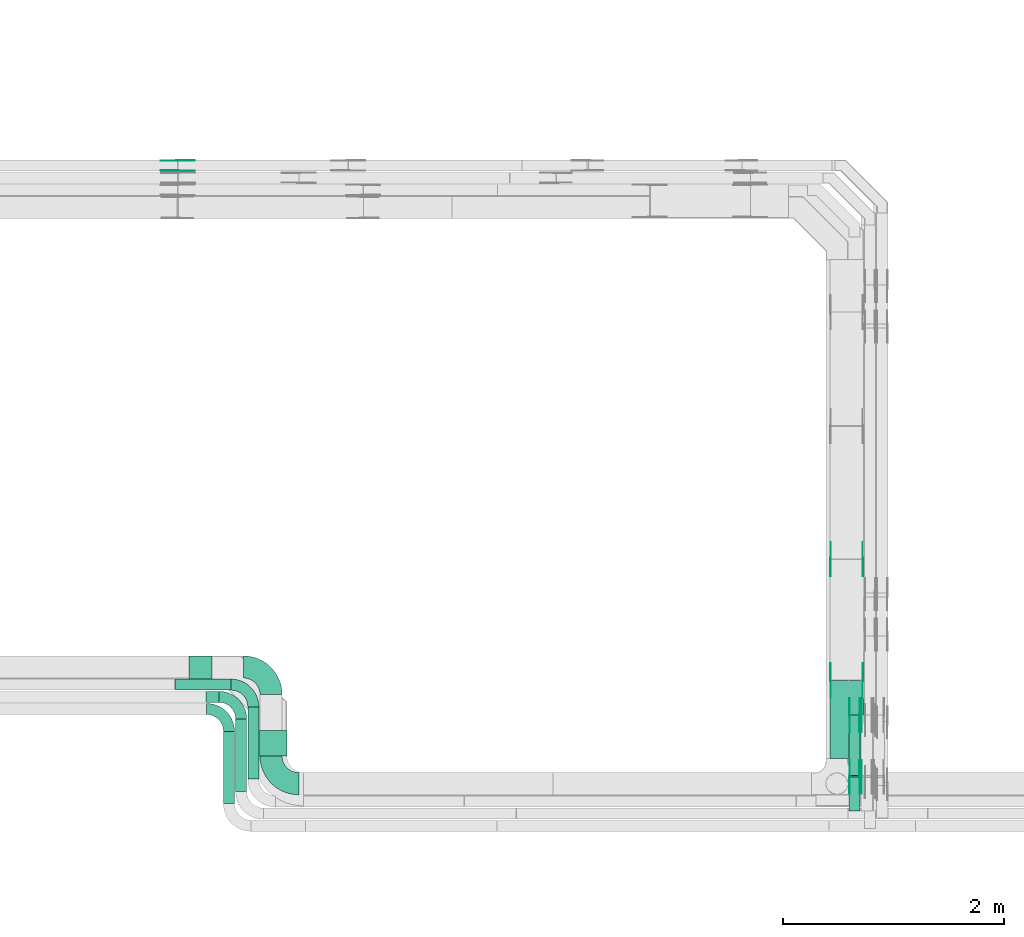
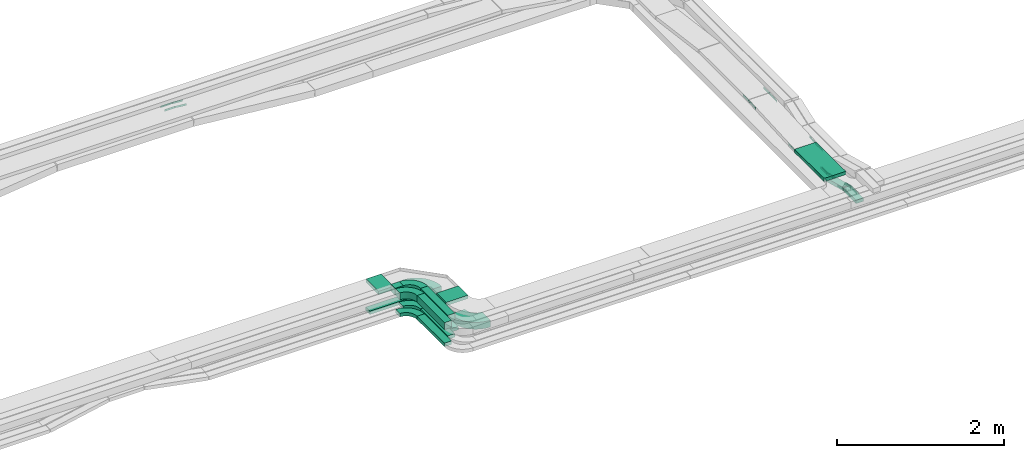
# One storey, part 23 of 33: 31 flow fittings, 12 flow segments.
"""IFC2X3 building model written with IfcOpenShell, lengths in millimetres."""

import ifcopenshell
import ifcopenshell.guid

model = None  # the IFC model being written
_history = None  # IfcOwnerHistory: only IFC2X3 demands one
_inside = {}  # id of a spatial element -> (the spatial element, [elements in it])
_under = {}  # id of a project, library or spatial element -> (it, [spatial elements below it])
_declared = {}  # id of a project -> (the project, [libraries it declares])
_typed = {}  # id of a type object -> (the type object, [elements of that type])
_made_of = {}  # id of a material, layer set ... -> (it, [elements and type objects made of it])


def new_model(schema):
    """Start an empty IFC model of exactly this schema.

    Asked for "IFC4X3", IfcOpenShell would pick the latest addendum, in which some entities
    have other attributes; the version numbers below select the first issue.
    IFC2X3 requires an IfcOwnerHistory on every rooted entity: one is made here for all.
    """
    global model, _history
    if schema == "IFC4X3":
        model = ifcopenshell.file(schema_version=(4, 3, 0, 0))
    else:
        model = ifcopenshell.file(schema=schema)
    _inside.clear()
    _under.clear()
    _declared.clear()
    _typed.clear()
    _made_of.clear()
    _history = None
    if model.schema == "IFC2X3":
        org = make("IfcOrganization", Name="unknown")
        user = make(
            "IfcPersonAndOrganization",
            ThePerson=make("IfcPerson", FamilyName="unknown"),
            TheOrganization=org,
        )
        app = make(
            "IfcApplication",
            ApplicationDeveloper=org,
            Version="unknown",
            ApplicationFullName="unknown",
            ApplicationIdentifier="unknown",
        )
        _history = make(
            "IfcOwnerHistory",
            OwningUser=user,
            OwningApplication=app,
            ChangeAction="ADDED",
            CreationDate=0,
        )
    return model


def make(cls, **values):
    """One entity of the class cls with the attributes given. An attribute that is None is left unset."""
    return model.create_entity(
        cls, **{name: value for name, value in values.items() if value is not None}
    )


def entity(cls, *values):
    """Any entity or typed value of the class cls, its attributes in the order of the schema. None: left unset."""
    e = model.create_entity(cls)
    for i, value in enumerate(values):
        if value is not None:
            e[i] = value
    return e


def rooted(cls, **values):
    """An entity with a GlobalId (a new one), such as an element, a storey or a relation."""
    return make(cls, GlobalId=ifcopenshell.guid.new(), OwnerHistory=_history, **values)


def si_unit(unit_type, name, prefix=None):
    """IfcSIUnit, for example si_unit("LENGTHUNIT", "METRE", prefix="MILLI")."""
    return make("IfcSIUnit", UnitType=unit_type, Prefix=prefix, Name=name)


def converted_unit(unit_type, name, factor, base, dimensions=None, offset=None):
    """IfcConversionBasedUnit, such as the inch: factor (a typed value) times the base unit."""
    return make(
        "IfcConversionBasedUnit"
        if offset is None
        else "IfcConversionBasedUnitWithOffset",
        ConversionOffset=offset,
        Dimensions=None
        if dimensions is None
        else entity("IfcDimensionalExponents", *dimensions),
        UnitType=unit_type,
        Name=name,
        ConversionFactor=make(
            "IfcMeasureWithUnit", ValueComponent=factor, UnitComponent=base
        ),
    )


def derived_unit(unit_type, elements):
    """IfcDerivedUnit: a product of units, each with its exponent."""
    return make(
        "IfcDerivedUnit",
        Elements=[
            make("IfcDerivedUnitElement", Unit=unit, Exponent=power)
            for unit, power in elements
        ],
        UnitType=unit_type,
    )


def assignment(units):
    """IfcUnitAssignment: the units of a project."""
    return None if units is None else make("IfcUnitAssignment", Units=units)


def point(xyz):
    """IfcCartesianPoint."""
    return None if xyz is None else make("IfcCartesianPoint", Coordinates=xyz)


def direction(xyz):
    """IfcDirection."""
    return None if xyz is None else make("IfcDirection", DirectionRatios=xyz)


def frame(location, z_axis=None, x_axis=None):
    """IfcAxis2Placement3D, a coordinate frame: its origin and axes. An axis left out is left unset."""
    return make(
        "IfcAxis2Placement3D",
        Location=point(location),
        Axis=direction(z_axis),
        RefDirection=direction(x_axis),
    )


def frame_2d(location, x_axis=None):
    """IfcAxis2Placement2D, a coordinate frame in the plane: its origin and x axis."""
    return make(
        "IfcAxis2Placement2D", Location=point(location), RefDirection=direction(x_axis)
    )


def origin():
    """The frame at (0, 0, 0) with its axes left unset."""
    return frame((0.0, 0.0, 0.0))


def origin_2d_with_axis():
    """The frame at (0, 0) in the plane with the x axis (1, 0) written out."""
    return frame_2d((0.0, 0.0), x_axis=(1.0, 0.0))


def place(relative_to, where):
    """IfcLocalPlacement: puts the frame where relative to a parent placement (None: the world)."""
    return make(
        "IfcLocalPlacement", PlacementRelTo=relative_to, RelativePlacement=where
    )


def context(
    kind, dimensions, precision=None, world=None, true_north=None, identifier=None
):
    """IfcGeometricRepresentationContext, for example the 3D "Model" context."""
    return make(
        "IfcGeometricRepresentationContext",
        ContextIdentifier=identifier,
        ContextType=kind,
        CoordinateSpaceDimension=dimensions,
        Precision=precision,
        WorldCoordinateSystem=world,
        TrueNorth=true_north,
    )


def subcontext(parent, identifier, kind, view, scale=None):
    """IfcGeometricRepresentationSubContext, for example "Body" below "Model"."""
    return make(
        "IfcGeometricRepresentationSubContext",
        ContextIdentifier=identifier,
        ContextType=kind,
        ParentContext=parent,
        TargetScale=scale,
        TargetView=view,
    )


def project(units=None, contexts=None):
    """IfcProject with its units and contexts."""
    return rooted(
        "IfcProject",
        Name="project",
        RepresentationContexts=contexts,
        UnitsInContext=assignment(units),
    )


def spatial(cls, under=None, at=None, **own):
    """A site, building, storey or space (cls), placed at a placement, below another one or the project."""
    s = rooted(cls, ObjectPlacement=at, **own)
    if under is not None:
        _under.setdefault(under.id(), (under, []))[1].append(s)
    return s


def polyline(points):
    """IfcPolyline through the points."""
    return make("IfcPolyline", Points=[point(p) for p in points])


def circle_curve(where, radius):
    """IfcCircle in the frame where."""
    return make("IfcCircle", Position=where, Radius=radius)


def parameter(value):
    """IfcParameterValue: where a trimmed curve begins or ends, as a parameter of its basis curve."""
    return model.create_entity("IfcParameterValue", value)


def trimmed(basis, trim1, trim2, sense, master):
    """IfcTrimmedCurve: the piece of a basis curve between two trims."""
    return make(
        "IfcTrimmedCurve",
        BasisCurve=basis,
        Trim1=trim1,
        Trim2=trim2,
        SenseAgreement=sense,
        MasterRepresentation=master,
    )


def segment(curve, same_sense, transition):
    """IfcCompositeCurveSegment."""
    return make(
        "IfcCompositeCurveSegment",
        Transition=transition,
        SameSense=same_sense,
        ParentCurve=curve,
    )


def composite_curve(segments, self_intersect=None):
    """IfcCompositeCurve: segments joined end to end."""
    return make("IfcCompositeCurve", Segments=segments, SelfIntersect=self_intersect)


def profile(cls, at=None, kind="AREA", **sizes):
    """A parametric profile (cls). Its sizes go by their IFC names, for example OverallWidth=200.0."""
    return make(cls, ProfileType=kind, Position=at, **sizes)


def rectangle(**sizes):
    """IfcRectangleProfileDef."""
    return profile("IfcRectangleProfileDef", **sizes)


def outline(outer, holes=None, kind="AREA"):
    """IfcArbitraryClosedProfileDef: a profile drawn as a closed curve; with holes, ...WithVoids."""
    if holes is None:
        return make("IfcArbitraryClosedProfileDef", ProfileType=kind, OuterCurve=outer)
    return make(
        "IfcArbitraryProfileDefWithVoids",
        ProfileType=kind,
        OuterCurve=outer,
        InnerCurves=holes,
    )


def extrude(swept, where, along, depth):
    """IfcExtrudedAreaSolid: the profile swept, set in the frame where, extruded along a direction by depth."""
    return make(
        "IfcExtrudedAreaSolid",
        SweptArea=swept,
        Position=where,
        ExtrudedDirection=direction(along),
        Depth=depth,
    )


def shape(context_of_items, identifier, shape_type, items):
    """IfcShapeRepresentation: the items that make up one representation, for example the "Body"."""
    return make(
        "IfcShapeRepresentation",
        ContextOfItems=context_of_items,
        RepresentationIdentifier=identifier,
        RepresentationType=shape_type,
        Items=items,
    )


def source(mapping_origin, context_of_items, identifier, shape_type, items):
    """IfcRepresentationMap: a shape defined once, which mapped items show again and again."""
    return make(
        "IfcRepresentationMap",
        MappingOrigin=mapping_origin,
        MappedRepresentation=shape(context_of_items, identifier, shape_type, items),
    )


def transform(
    local_origin,
    x_axis=None,
    y_axis=None,
    z_axis=None,
    scale=None,
    scale2=None,
    scale3=None,
    uniform=True,
):
    """IfcCartesianTransformationOperator3D, or its non-uniform kind. x_axis, y_axis, z_axis: its Axis1, 2, 3."""
    if uniform:
        return make(
            "IfcCartesianTransformationOperator3D",
            Axis1=direction(x_axis),
            Axis2=direction(y_axis),
            LocalOrigin=point(local_origin),
            Scale=scale,
            Axis3=direction(z_axis),
        )
    return make(
        "IfcCartesianTransformationOperator3DnonUniform",
        Axis1=direction(x_axis),
        Axis2=direction(y_axis),
        LocalOrigin=point(local_origin),
        Scale=scale,
        Axis3=direction(z_axis),
        Scale2=scale2,
        Scale3=scale3,
    )


def mapped(mapping_source, mapping_target):
    """IfcMappedItem: shows the shape of a source again, moved by a transform."""
    return make(
        "IfcMappedItem", MappingSource=mapping_source, MappingTarget=mapping_target
    )


def material(Name=None, Category=None):
    """IfcMaterial."""
    return make("IfcMaterial", Name=Name, Category=Category)


def made_of(thing, what):
    """Note that an element or type object is made of a material, layer set ...; save() writes the relation."""
    if what is not None:
        _made_of.setdefault(what.id(), (what, []))[1].append(thing)
    return thing


def type_object(cls, material=None, **own):
    """A type object (cls), such as IfcWallType, which elements share."""
    return made_of(rooted(cls, **own), material)


def type_shapes(of_type, sources):
    """Give a type object the sources (RepresentationMaps) that its elements show as mapped items."""
    of_type.RepresentationMaps = sources


def element(
    cls,
    number,
    at=None,
    inside=None,
    cuts=None,
    type_object=None,
    material=None,
    context=None,
    identifier="Body",
    shape_type=None,
    held_by="IfcProductDefinitionShape",
    body=None,
    shapes=None,
    **own,
):
    """One element of the class cls, such as IfcWall. Its Tag is "e" and its number.

    at: its placement. inside: the storey or other place that contains it. cuts: it is an
    opening in that element (IfcRelVoidsElement). A single representation is given by context,
    identifier, shape_type and body (its items); several are given by shapes. held_by: the class
    of the entity that holds the representations. save() writes the other relations.
    """
    e = rooted(cls, Tag="e%d" % number, ObjectPlacement=at, **own)
    if body is not None:
        shapes = [shape(context, identifier, shape_type, body)]
    if shapes is not None:
        e.Representation = make(held_by, Representations=shapes)
    if inside is not None:
        _inside.setdefault(inside.id(), (inside, []))[1].append(e)
    if cuts is not None:
        rooted(
            "IfcRelVoidsElement", RelatingBuildingElement=cuts, RelatedOpeningElement=e
        )
    if type_object is not None:
        _typed.setdefault(type_object.id(), (type_object, []))[1].append(e)
    return made_of(e, material)


def aggregate(whole, parts):
    """IfcRelAggregates: a whole, such as a stair, and the parts it consists of."""
    return rooted("IfcRelAggregates", RelatingObject=whole, RelatedObjects=parts)


def save(model, path):
    """Write the relations noted so far, then the file.

    IfcRelAggregates (storeys below a building ...), IfcRelContainedInSpatialStructure (elements
    in a storey), IfcRelDefinesByType, IfcRelAssociatesMaterial and IfcRelDeclares: one each for
    every whole, place, type object, material and project.
    """
    for whole, parts in _under.values():
        aggregate(whole, parts)
    for where, things in _inside.values():
        rooted(
            "IfcRelContainedInSpatialStructure",
            RelatedElements=things,
            RelatingStructure=where,
        )
    for kind, things in _typed.values():
        rooted("IfcRelDefinesByType", RelatedObjects=things, RelatingType=kind)
    for what, things in _made_of.values():
        rooted("IfcRelAssociatesMaterial", RelatedObjects=things, RelatingMaterial=what)
    for by, libraries in _declared.values():
        rooted("IfcRelDeclares", RelatingContext=by, RelatedDefinitions=libraries)
    model.write(path)


model = new_model("IFC2X3")

# Units and contexts
model_context = context("Model", 3, precision=0.01, world=origin(), true_north=direction((6.12303176911189e-17, 1.0)))
body_context = subcontext(model_context, "Body", "Model", "MODEL_VIEW")
ifc_project = project(units=[si_unit("LENGTHUNIT", "METRE", prefix="MILLI"), si_unit("AREAUNIT", "SQUARE_METRE"), si_unit("VOLUMEUNIT", "CUBIC_METRE"), converted_unit("PLANEANGLEUNIT", "DEGREE", entity("IfcRatioMeasure", 0.0174532925199433), si_unit("PLANEANGLEUNIT", "RADIAN"), dimensions=[0, 0, 0, 0, 0, 0, 0]), si_unit("MASSUNIT", "GRAM", prefix="KILO"), derived_unit("MASSDENSITYUNIT", [(si_unit("MASSUNIT", "GRAM", prefix="KILO"), 1), (si_unit("LENGTHUNIT", "METRE"), -3)]), derived_unit("MOMENTOFINERTIAUNIT", [(si_unit("LENGTHUNIT", "METRE"), 4)]), si_unit("TIMEUNIT", "SECOND"), si_unit("FREQUENCYUNIT", "HERTZ"), si_unit("THERMODYNAMICTEMPERATUREUNIT", "DEGREE_CELSIUS"), derived_unit("THERMALTRANSMITTANCEUNIT", [(si_unit("MASSUNIT", "GRAM", prefix="KILO"), 1), (si_unit("THERMODYNAMICTEMPERATUREUNIT", "KELVIN"), -1), (si_unit("TIMEUNIT", "SECOND"), -3)]), derived_unit("VOLUMETRICFLOWRATEUNIT", [(si_unit("LENGTHUNIT", "METRE"), 3), (si_unit("TIMEUNIT", "SECOND"), -1)]), derived_unit("MASSFLOWRATEUNIT", [(si_unit("MASSUNIT", "GRAM", prefix="KILO"), 1), (si_unit("TIMEUNIT", "SECOND"), -1)]), derived_unit("ROTATIONALFREQUENCYUNIT", [(si_unit("TIMEUNIT", "SECOND"), -1)]), si_unit("ELECTRICCURRENTUNIT", "AMPERE"), si_unit("ELECTRICVOLTAGEUNIT", "VOLT"), si_unit("POWERUNIT", "WATT"), si_unit("FORCEUNIT", "NEWTON", prefix="KILO"), si_unit("ILLUMINANCEUNIT", "LUX"), si_unit("LUMINOUSFLUXUNIT", "LUMEN"), si_unit("LUMINOUSINTENSITYUNIT", "CANDELA"), derived_unit("USERDEFINED", [(si_unit("MASSUNIT", "GRAM", prefix="KILO"), -1), (si_unit("LENGTHUNIT", "METRE"), -2), (si_unit("TIMEUNIT", "SECOND"), 3), (si_unit("LUMINOUSFLUXUNIT", "LUMEN"), 1)]), derived_unit("LINEARVELOCITYUNIT", [(si_unit("LENGTHUNIT", "METRE"), 1), (si_unit("TIMEUNIT", "SECOND"), -1)]), si_unit("PRESSUREUNIT", "PASCAL"), derived_unit("USERDEFINED", [(si_unit("LENGTHUNIT", "METRE"), -2), (si_unit("MASSUNIT", "GRAM", prefix="KILO"), 1), (si_unit("TIMEUNIT", "SECOND"), -2)]), derived_unit("LINEARFORCEUNIT", [(si_unit("MASSUNIT", "GRAM", prefix="KILO"), 1), (si_unit("LENGTHUNIT", "METRE"), 1), (si_unit("TIMEUNIT", "SECOND"), -2), (si_unit("LENGTHUNIT", "METRE"), -1)]), derived_unit("PLANARFORCEUNIT", [(si_unit("MASSUNIT", "GRAM", prefix="KILO"), 1), (si_unit("LENGTHUNIT", "METRE"), 1), (si_unit("TIMEUNIT", "SECOND"), -2), (si_unit("LENGTHUNIT", "METRE"), -2)])], contexts=[model_context])

# Site, building, storey
site_placement = place(None, frame((0.0, -0.00077364408347762, 0.0)))
site = spatial("IfcSite", under=ifc_project, at=site_placement, CompositionType="ELEMENT")
building_placement = place(site_placement, origin())
building = spatial("IfcBuilding", under=site, at=building_placement, CompositionType="ELEMENT")
storey_placement = place(building_placement, frame((0.0, 0.0, 8100.0)))
storey = spatial("IfcBuildingStorey", under=building, at=storey_placement, CompositionType="ELEMENT", Elevation=8100.0)

# Flow segments
cable_carrier_segment_type = type_object("IfcCableCarrierSegmentType", PredefinedType="CABLETRAYSEGMENT")
flow_segment_1_placement = place(storey_placement, frame((55040.108534959, 9110.97860618822, 2549.87332137863)))
element("IfcFlowSegment", 1, at=flow_segment_1_placement, inside=storey, type_object=cable_carrier_segment_type, context=body_context, shape_type="SweptSolid", body=[
    extrude(rectangle(XDim=653.020769727202, YDim=99.9999999999946, at=origin_2d_with_axis()), frame((50.0, 326.510384863601, 0.0), z_axis=(0.0, 0.0, 1.0), x_axis=(0.0, 1.0, 0.0)), (0.0, 0.0, 1.0), 50.0000000000016),
])
flow_segment_2_placement = place(storey_placement, frame((54930.108534959, 9000.97860618822, 2549.86934553523)))
element("IfcFlowSegment", 2, at=flow_segment_2_placement, inside=storey, type_object=cable_carrier_segment_type, context=body_context, shape_type="SweptSolid", body=[
    extrude(rectangle(XDim=653.020769727214, YDim=99.9999999999946, at=frame_2d((5.40012479177676e-13, 0.0), x_axis=(1.0, 0.0))), frame((50.0, 326.510384863607, 0.0), z_axis=(0.0, 0.0, 1.0), x_axis=(0.0, 1.0, 0.0)), (0.0, 0.0, 1.0), 50.0000000000016),
])
flow_segment_3_placement = place(storey_placement, frame((54820.108534959, 8890.98005285077, 2548.15905189632)))
element("IfcFlowSegment", 3, at=flow_segment_3_placement, inside=storey, type_object=cable_carrier_segment_type, context=body_context, shape_type="SweptSolid", body=[
    extrude(rectangle(XDim=653.019323064651, YDim=99.9999999999946, at=origin_2d_with_axis()), frame((50.0, 326.509661532326, 0.0), z_axis=(0.0, 0.0, 1.0), x_axis=(0.0, 1.0, 0.0)), (0.0, 0.0, 1.0), 50.0000000000016),
])
flow_segment_4_placement = place(storey_placement, frame((55092.3432276788, 9320.53690834164, 2789.10332100711)))
element("IfcFlowSegment", 4, at=flow_segment_4_placement, inside=storey, type_object=cable_carrier_segment_type, context=body_context, shape_type="SweptSolid", body=[
    extrude(rectangle(XDim=228.305561513048, YDim=299.999999999992, at=frame_2d((1.09423581307055e-12, 4.33431068813661e-12), x_axis=(1.0, 0.0))), frame((150.108094808578, 114.325350365824, 0.0696650792277069), z_axis=(5.78252488002628e-07, -0.0006102790268846, 0.99999981377957), x_axis=(-0.000947520880238993, 0.999999364881477, 0.000610279300837866)), (0.0, 0.0, 1.0), 50.0000000000009),
])
flow_segment_5_placement = place(storey_placement, frame((54930.3347331042, 9000.96836297341, 2799.84453970333)))
element("IfcFlowSegment", 5, at=flow_segment_5_placement, inside=storey, type_object=cable_carrier_segment_type, context=body_context, shape_type="SweptSolid", body=[
    extrude(rectangle(XDim=653.020791015254, YDim=99.9999999999946, at=frame_2d((5.40012479177676e-13, 0.0), x_axis=(1.0, 0.0))), frame((50.0, 326.510388661624, 0.0668624207678022), z_axis=(0.0, 0.000204778842239003, 0.999999979032813), x_axis=(0.0, -0.999999979032813, 0.000204778842239003)), (0.0, 0.0, 1.0), 100.000000000001),
])
flow_segment_6_placement = place(storey_placement, frame((54820.1084907721, 8890.96834425164, 2799.31810862612)))
element("IfcFlowSegment", 6, at=flow_segment_6_placement, inside=storey, type_object=cable_carrier_segment_type, context=body_context, shape_type="SweptSolid", body=[
    extrude(rectangle(XDim=653.022106435861, YDim=99.999999999999, at=frame_2d((5.40012479177676e-13, 0.0), x_axis=(1.0, 0.0))), frame((50.0, 326.511046377189, 0.0669251590355884), z_axis=(8.83740140805357e-07, 0.000204835246373141, 0.99999997902087), x_axis=(0.0, -0.999999979021261, 0.000204835246373221)), (0.0, 0.0, 1.0), 99.9999999999998),
])
flow_segment_7_placement = place(storey_placement, frame((60300.1085349485, 9299.97860618826, 2788.91979567565)))
element("IfcFlowSegment", 7, at=flow_segment_7_placement, inside=storey, type_object=cable_carrier_segment_type, context=body_context, shape_type="SweptSolid", body=[
    extrude(rectangle(XDim=704.194438321864, YDim=300.000000000001, at=frame_2d((-5.40012479177676e-13, 0.0), x_axis=(1.0, 0.0))), frame((150.0, 352.097219160932, 0.0), z_axis=(0.0, 0.0, 1.0), x_axis=(0.0, 1.0, 0.0)), (0.0, 0.0, 1.0), 50.0000000000016),
])
flow_segment_8_placement = place(storey_placement, frame((54382.0608098118, 9914.99937591542, 2549.87332137863)))
element("IfcFlowSegment", 8, at=flow_segment_8_placement, inside=storey, type_object=cable_carrier_segment_type, context=body_context, shape_type="SweptSolid", body=[
    extrude(rectangle(XDim=507.047725147146, YDim=99.9999999999989, at=frame_2d((4.33431068813661e-12, 0.0), x_axis=(1.0, 0.0))), frame((253.523862573568, 50.0, 0.0)), (0.0, 0.0, 1.0), 50.0000000000016),
])
flow_segment_9_placement = place(storey_placement, frame((54664.8615172535, 9804.99937591546, 2799.80775144899)))
element("IfcFlowSegment", 9, at=flow_segment_9_placement, inside=storey, type_object=cable_carrier_segment_type, context=body_context, shape_type="SweptSolid", body=[
    extrude(rectangle(XDim=114.4721271414, YDim=99.9999999999989, at=origin_2d_with_axis()), frame((57.236063557152, 50.0, 0.00124533418943429)), (0.0, 0.0, 1.0), 99.9999999999998),
])
flow_segment_10_placement = place(storey_placement, frame((60470.1085349485, 8826.02609150699, 2697.68139712069)))
element("IfcFlowSegment", 10, at=flow_segment_10_placement, inside=storey, type_object=cable_carrier_segment_type, context=body_context, shape_type="SweptSolid", body=[
    extrude(rectangle(XDim=300.444409805727, YDim=99.9999999999946, at=frame_2d((-5.40012479177676e-13, 0.0), x_axis=(1.0, 0.0))), frame((50.0, 150.222204902864, 0.0), z_axis=(0.0, 0.0, 1.0), x_axis=(0.0, -1.0, 0.0)), (0.0, 0.0, 1.0), 50.0000000000016),
])
flow_segment_11_placement = place(storey_placement, frame((60470.1085349485, 9129.46130477396, 2552.05597275502)))
element("IfcFlowSegment", 11, at=flow_segment_11_placement, inside=storey, type_object=cable_carrier_segment_type, context=body_context, shape_type="SweptSolid", body=[
    extrude(rectangle(XDim=50.0000000000033, YDim=567.25321482059, at=frame_2d((0.0, 0.0), x_axis=(0.0, 1.0))), frame((0.0, 280.573556284615, 96.7847258052534), z_axis=(1.0, 0.0, 0.0), x_axis=(0.0, 0.966667799264399, -0.256033915459111)), (0.0, 0.0, 1.0), 99.9999999999946),
])
flow_segment_12_placement = place(storey_placement, frame((54509.6066594756, 9924.50134983417, 2789.6776478881)))
element("IfcFlowSegment", 12, at=flow_segment_12_placement, inside=storey, type_object=cable_carrier_segment_type, context=body_context, shape_type="SweptSolid", body=[
    extrude(rectangle(XDim=205.870314110573, YDim=299.999999999673, at=frame_2d((4.33431068813661e-12, 1.09423581307055e-12), x_axis=(1.0, 0.0))), frame((103.298041940791, 150.248793330496, 0.0226138749251959), z_axis=(0.000218923897814859, -3.57656509615694e-09, 0.999999976036163), x_axis=(0.999997044780487, -0.0024212606005856, -0.000218923264752722)), (0.0, 0.0, 1.0), 49.9999999999447),
])

# Flow fittings
ifc_material_1 = material()
cable_carrier_fitting_type_1 = type_object("IfcCableCarrierFittingType", Name="470_DKC_S5_Variable Angle Elbow 0-45:-", PredefinedType="NOTDEFINED", material=ifc_material_1)
shared_shape_1 = source(origin(), body_context, "Body", "SweptSolid", [
    extrude(outline(composite_curve([segment(polyline([(-125.750000000001, -225.25), (-124.749999999999, -225.25)]), True, "CONTINUOUS"), segment(trimmed(circle_curve(frame_2d((-124.75, 124.75), x_axis=(0.0, -1.0)), 350.0), [parameter(0.0)], [parameter(90.0000000000001)], True, "PARAMETER"), True, "CONTINUOUS"), segment(polyline([(225.25, 124.75), (225.25, 125.749999999999)]), True, "CONTINUOUS"), segment(polyline([(225.25, 125.749999999999), (25.25, 125.750000000001)]), True, "CONTINUOUS"), segment(polyline([(25.25, 125.750000000001), (25.25, 124.75)]), True, "CONTINUOUS"), segment(trimmed(circle_curve(frame_2d((-124.75, 124.75), x_axis=(0.0, -1.0)), 150.0), [parameter(0.0)], [parameter(90.0000000000001)], True, "PARAMETER"), False, "CONTINUOUS"), segment(polyline([(-124.749999999999, -25.2500000000003), (-125.750000000001, -25.2500000000003)]), True, "CONTINUOUS"), segment(polyline([(-125.750000000001, -25.2500000000003), (-125.750000000001, -225.25)]), True, "CONTINUOUS")], self_intersect=False)), frame((-125.249999999991, 125.249999999992, -50.0)), (0.0, 0.0, 1.0), 100.0),
])
type_shapes(cable_carrier_fitting_type_1, [shared_shape_1])
flow_fitting_1_placement = place(storey_placement, frame((55250.108534959, 9069.9786061882, 2599.83876380786), z_axis=(0.0, 0.0, 1.0), x_axis=(0.0, -1.0, 0.0)))
element("IfcFlowFitting", 13, at=flow_fitting_1_placement, inside=storey, type_object=cable_carrier_fitting_type_1, material=ifc_material_1, Name="470_DKC_S5_Variable Angle Elbow 0-45:-", ObjectType="470_DKC_S5_Variable Angle Elbow 0-45:-", context=body_context, shape_type="MappedRepresentation", body=[
    mapped(shared_shape_1, transform((0.0, 0.0, 0.0), scale=1.0)),
])
cable_carrier_fitting_type_2 = type_object("IfcCableCarrierFittingType", Name="470_DKC_S5_Variable Angle Elbow 0-45:-", PredefinedType="NOTDEFINED", material=ifc_material_1)
shared_shape_2 = source(origin(), body_context, "Body", "SweptSolid", [
    extrude(outline(composite_curve([segment(polyline([(-100.750000000001, -150.25), (-99.7499999999994, -150.25)]), True, "CONTINUOUS"), segment(trimmed(circle_curve(frame_2d((-99.7499999999997, 99.7499999999995), x_axis=(0.0, -1.0)), 250.0), [parameter(0.0)], [parameter(90.0000000000001)], True, "PARAMETER"), True, "CONTINUOUS"), segment(polyline([(150.25, 99.75), (150.25, 100.749999999999)]), True, "CONTINUOUS"), segment(polyline([(150.25, 100.749999999999), (50.25, 100.75)]), True, "CONTINUOUS"), segment(polyline([(50.25, 100.75), (50.25, 99.7499999999998)]), True, "CONTINUOUS"), segment(trimmed(circle_curve(frame_2d((-99.7499999999997, 99.7499999999995), x_axis=(0.0, -1.0)), 150.0), [parameter(0.0)], [parameter(90.0000000000001)], True, "PARAMETER"), False, "CONTINUOUS"), segment(polyline([(-99.7499999999994, -50.2500000000003), (-100.750000000001, -50.2500000000003)]), True, "CONTINUOUS"), segment(polyline([(-100.750000000001, -50.2500000000003), (-100.750000000001, -150.25)]), True, "CONTINUOUS")], self_intersect=False)), frame((-100.249999999991, 100.249999999992, -25.0)), (0.0, 0.0, 1.0), 49.9999999999997),
])
type_shapes(cable_carrier_fitting_type_2, [shared_shape_2])
flow_fitting_2_placement = place(storey_placement, frame((55090.108534959, 9964.99937591541, 2574.87332137863), z_axis=(0.0, 0.0, 1.0), x_axis=(0.0, 1.0, 0.0)))
element("IfcFlowFitting", 14, at=flow_fitting_2_placement, inside=storey, type_object=cable_carrier_fitting_type_2, material=ifc_material_1, Name="470_DKC_S5_Variable Angle Elbow 0-45:-", ObjectType="470_DKC_S5_Variable Angle Elbow 0-45:-", context=body_context, shape_type="MappedRepresentation", body=[
    mapped(shared_shape_2, transform((0.0, 0.0, 0.0), scale=1.0)),
])
ifc_material_2 = material(Name="G")
cable_carrier_fitting_type_3 = type_object("IfcCableCarrierFittingType", PredefinedType="NOTDEFINED", material=ifc_material_2)
shared_shape_3 = source(origin(), body_context, "Body", "SweptSolid", [
    extrude(outline(composite_curve([segment(trimmed(circle_curve(frame_2d((-44.5901162790698, 0.0), x_axis=(1.0, 0.0)), 12.5), [parameter(90.0000000000007)], [parameter(270.0)], True, "PARAMETER"), True, "CONTINUOUS"), segment(polyline([(-44.5901162790697, -12.5), (-33.0901162790698, -12.5)]), True, "CONTINUOUS"), segment(polyline([(-33.0901162790698, -12.5), (-31.2296511627907, -14.5)]), True, "CONTINUOUS"), segment(polyline([(-31.2296511627907, -14.5), (108.90988372093, -14.5)]), True, "CONTINUOUS"), segment(polyline([(108.90988372093, -14.5), (108.90988372093, 14.5)]), True, "CONTINUOUS"), segment(polyline([(108.90988372093, 14.5), (-31.2296511627907, 14.5)]), True, "CONTINUOUS"), segment(polyline([(-31.2296511627907, 14.5), (-33.0901162790698, 12.5)]), True, "CONTINUOUS"), segment(polyline([(-33.0901162790698, 12.5), (-44.5901162790699, 12.5)]), True, "CONTINUOUS")], self_intersect=False)), frame((44.5901162790698, 0.0, 0.0), z_axis=(0.0, 0.0, -1.0), x_axis=(1.0, 0.0, 0.0)), (0.0, 0.0, -1.0), 2.0),
])
type_shapes(cable_carrier_fitting_type_3, [shared_shape_3])
for number, where, z_axis, x_axis in (
    (15, (60565.5685349586, 9131.2459145021, 2722.68139712075), (1.0, 0.0, 0.0), (0.0, -1.0, 0.0)),
    (16, (60565.5685349586, 9688.82380761497, 2575.0), (1.0, 0.0, 0.0), (0.0, 1.0, 0.0)),
    (17, (54405.8774534123, 14697.7382357574, 2729.50214316132), (0.0, 1.0, 0.0), (0.995008976455459, 0.0, -0.0997854537147592)),
    (18, (60595.5685349587, 11099.3073355502, 2874.7076472145), (1.0, 0.0, 0.0), (0.0, -0.998457956531639, -0.0555131429362853)),
    (19, (60595.5685349587, 10005.9786061882, 2813.91979567564), (1.0, 0.0, 0.0), (0.0, 0.998457956531639, 0.0555131429362853)),
):
    element("IfcFlowFitting", number, at=place(storey_placement, frame(where, z_axis=z_axis, x_axis=x_axis)), inside=storey, type_object=cable_carrier_fitting_type_3, material=ifc_material_2, context=body_context, shape_type="MappedRepresentation", body=[
        mapped(shared_shape_3, transform((0.0, 0.0, 0.0), scale=1.0)),
    ])
cable_carrier_fitting_type_4 = type_object("IfcCableCarrierFittingType", PredefinedType="NOTDEFINED", material=ifc_material_2)
shared_shape_4 = source(origin(), body_context, "Body", "SweptSolid", [
    extrude(outline(composite_curve([segment(trimmed(circle_curve(frame_2d((-44.5901162790697, 0.0), x_axis=(1.0, 0.0)), 12.5), [parameter(90.0000000000007)], [parameter(270.0)], True, "PARAMETER"), True, "CONTINUOUS"), segment(polyline([(-44.5901162790697, -12.5), (-33.0901162790697, -12.5)]), True, "CONTINUOUS"), segment(polyline([(-33.0901162790697, -12.5), (-31.2296511627907, -14.5)]), True, "CONTINUOUS"), segment(polyline([(-31.2296511627907, -14.5), (108.90988372093, -14.5)]), True, "CONTINUOUS"), segment(polyline([(108.90988372093, -14.5), (108.90988372093, 14.5)]), True, "CONTINUOUS"), segment(polyline([(108.90988372093, 14.5), (-31.2296511627907, 14.5)]), True, "CONTINUOUS"), segment(polyline([(-31.2296511627907, 14.5), (-33.0901162790698, 12.5)]), True, "CONTINUOUS"), segment(polyline([(-33.0901162790698, 12.5), (-44.5901162790699, 12.5)]), True, "CONTINUOUS")], self_intersect=False)), frame((44.5901162790697, 0.0, 0.0)), (0.0, 0.0, 1.0), 2.0),
])
type_shapes(cable_carrier_fitting_type_4, [shared_shape_4])
for number, where, z_axis, x_axis in (
    (20, (60584.6485349383, 9131.2459145021, 2722.68139712075), (-1.0, 0.0, 0.0), (0.0, -1.0, 0.0)),
    (21, (60474.6485349383, 9131.24591450211, 2722.68139712076), (-1.0, 0.0, 0.0), (0.0, -1.0, 0.0)),
    (22, (60474.6485349383, 9688.82380761497, 2575.0), (-1.0, 0.0, 0.0), (0.0, 1.0, 0.0)),
    (23, (60584.6485349383, 9688.82380761497, 2575.0), (-1.0, 0.0, 0.0), (0.0, 1.0, 0.0)),
    (24, (54405.8774534123, 14606.8182357371, 2729.50214316132), (0.0, -1.0, 0.0), (0.995008976455459, 0.0, -0.0997854537147592)),
    (25, (60304.6485349384, 11099.3073355502, 2874.7076472145), (-1.0, 0.0, 0.0), (0.0, -0.998457956531639, -0.0555131429362853)),
    (26, (60304.6485349384, 10005.9786061882, 2813.91979567564), (-1.0, 0.0, 0.0), (0.0, 0.998457956531639, 0.0555131429362853)),
):
    element("IfcFlowFitting", number, at=place(storey_placement, frame(where, z_axis=z_axis, x_axis=x_axis)), inside=storey, type_object=cable_carrier_fitting_type_4, material=ifc_material_2, context=body_context, shape_type="MappedRepresentation", body=[
        mapped(shared_shape_4, transform((0.0, 0.0, 0.0), scale=1.0)),
    ])
cable_carrier_fitting_type_5 = type_object("IfcCableCarrierFittingType", PredefinedType="NOTDEFINED", material=ifc_material_2)
shared_shape_5 = source(origin(), body_context, "Body", "SweptSolid", [
    extrude(outline(composite_curve([segment(trimmed(circle_curve(frame_2d((-44.5901162790698, 0.0), x_axis=(1.0, 0.0)), 12.5), [parameter(90.0000000000007)], [parameter(270.0)], True, "PARAMETER"), True, "CONTINUOUS"), segment(polyline([(-44.5901162790697, -12.5), (-33.0901162790698, -12.5)]), True, "CONTINUOUS"), segment(polyline([(-33.0901162790698, -12.5), (-31.2296511627907, -14.5)]), True, "CONTINUOUS"), segment(polyline([(-31.2296511627907, -14.5), (108.90988372093, -14.5)]), True, "CONTINUOUS"), segment(polyline([(108.90988372093, -14.5), (108.90988372093, 14.5)]), True, "CONTINUOUS"), segment(polyline([(108.90988372093, 14.5), (-31.2296511627907, 14.5)]), True, "CONTINUOUS"), segment(polyline([(-31.2296511627907, 14.5), (-33.0901162790698, 12.5)]), True, "CONTINUOUS"), segment(polyline([(-33.0901162790698, 12.5), (-44.5901162790699, 12.5)]), True, "CONTINUOUS")], self_intersect=False)), frame((44.5901162790698, 0.0, 0.0), z_axis=(0.0, 0.0, -1.0), x_axis=(1.0, 0.0, 0.0)), (0.0, 0.0, -1.0), 2.0),
])
type_shapes(cable_carrier_fitting_type_5, [shared_shape_5])
for number, where, z_axis, x_axis in (
    (27, (60586.6485349383, 9131.24591450208, 2722.68139712075), (-1.0, 0.0, 0.0), (0.0, 0.966667799263134, -0.256033915463888)),
    (28, (60476.6485349383, 9131.24591450209, 2722.68139712076), (-1.0, 0.0, 0.0), (0.0, 0.966667799263134, -0.256033915463888)),
    (29, (60476.6485349383, 9688.82380761499, 2575.0), (-1.0, 0.0, 0.0), (0.0, -0.966667799264405, 0.256033915459091)),
    (30, (60586.6485349383, 9688.82380761499, 2575.0), (-1.0, 0.0, 0.0), (0.0, -0.966667799264405, 0.256033915459089)),
    (31, (54405.8774534123, 14608.8182357371, 2729.50214316131), (0.0, -1.0, 0.0), (-1.0, 0.0, 0.0)),
    (32, (60306.6485349383, 11099.3073355502, 2874.70764721449), (-1.0, 0.0, 0.0), (0.0, 1.0, 0.0)),
    (33, (60306.6485349383, 10005.9786061883, 2813.91979567564), (-1.0, 0.0, 0.0), (0.0, -1.0, 0.0)),
):
    element("IfcFlowFitting", number, at=place(storey_placement, frame(where, z_axis=z_axis, x_axis=x_axis)), inside=storey, type_object=cable_carrier_fitting_type_5, material=ifc_material_2, context=body_context, shape_type="MappedRepresentation", body=[
        mapped(shared_shape_5, transform((0.0, 0.0, 0.0), scale=1.0)),
    ])
cable_carrier_fitting_type_6 = type_object("IfcCableCarrierFittingType", PredefinedType="NOTDEFINED", material=ifc_material_2)
shared_shape_6 = source(origin(), body_context, "Body", "SweptSolid", [
    extrude(outline(composite_curve([segment(trimmed(circle_curve(frame_2d((-44.5901162790697, 0.0), x_axis=(1.0, 0.0)), 12.5), [parameter(90.0000000000007)], [parameter(270.0)], True, "PARAMETER"), True, "CONTINUOUS"), segment(polyline([(-44.5901162790697, -12.5), (-33.0901162790697, -12.5)]), True, "CONTINUOUS"), segment(polyline([(-33.0901162790697, -12.5), (-31.2296511627907, -14.5)]), True, "CONTINUOUS"), segment(polyline([(-31.2296511627907, -14.5), (108.90988372093, -14.5)]), True, "CONTINUOUS"), segment(polyline([(108.90988372093, -14.5), (108.90988372093, 14.5)]), True, "CONTINUOUS"), segment(polyline([(108.90988372093, 14.5), (-31.2296511627907, 14.5)]), True, "CONTINUOUS"), segment(polyline([(-31.2296511627907, 14.5), (-33.0901162790698, 12.5)]), True, "CONTINUOUS"), segment(polyline([(-33.0901162790698, 12.5), (-44.5901162790699, 12.5)]), True, "CONTINUOUS")], self_intersect=False)), frame((44.5901162790697, 0.0, 0.0)), (0.0, 0.0, 1.0), 2.0),
])
type_shapes(cable_carrier_fitting_type_6, [shared_shape_6])
for number, where, z_axis, x_axis in (
    (34, (60563.5685349586, 9131.24591450209, 2722.68139712075), (1.0, 0.0, 0.0), (0.0, 0.966667799263134, -0.256033915463888)),
    (35, (60563.5685349586, 9688.82380761499, 2575.0), (1.0, 0.0, 0.0), (0.0, -0.966667799264405, 0.256033915459091)),
    (36, (54405.8774534123, 14695.7382357574, 2729.50214316131), (0.0, 1.0, 0.0), (-1.0, 0.0, 0.0)),
    (37, (60593.5685349587, 11099.3073355502, 2874.70764721449), (1.0, 0.0, 0.0), (0.0, 1.0, 0.0)),
    (38, (60593.5685349587, 10005.9786061883, 2813.91979567564), (1.0, 0.0, 0.0), (0.0, -1.0, 0.0)),
):
    element("IfcFlowFitting", number, at=place(storey_placement, frame(where, z_axis=z_axis, x_axis=x_axis)), inside=storey, type_object=cable_carrier_fitting_type_6, material=ifc_material_2, context=body_context, shape_type="MappedRepresentation", body=[
        mapped(shared_shape_6, transform((0.0, 0.0, 0.0), scale=1.0)),
    ])
cable_carrier_fitting_type_7 = type_object("IfcCableCarrierFittingType", Name="470_DKC_S5_Variable Angle Elbow 0-45:-", PredefinedType="NOTDEFINED", material=ifc_material_1)
shared_shape_7 = source(origin(), body_context, "Body", "SweptSolid", [
    extrude(outline(composite_curve([segment(polyline([(-100.749999999999, -150.250000000001), (-99.7499999999981, -150.250000000001)]), True, "CONTINUOUS"), segment(trimmed(circle_curve(frame_2d((-99.7500000000006, 99.7499999999987), x_axis=(0.0, -1.0)), 250.0), [parameter(0.0)], [parameter(90.0000000000001)], True, "PARAMETER"), True, "CONTINUOUS"), segment(polyline([(150.249999999999, 99.7500000000013), (150.249999999999, 100.750000000001)]), True, "CONTINUOUS"), segment(polyline([(150.249999999999, 100.750000000001), (50.2499999999992, 100.750000000001)]), True, "CONTINUOUS"), segment(polyline([(50.2499999999992, 100.750000000001), (50.2499999999992, 99.7500000000002)]), True, "CONTINUOUS"), segment(trimmed(circle_curve(frame_2d((-99.7500000000006, 99.7499999999987), x_axis=(0.0, -1.0)), 150.0), [parameter(0.0)], [parameter(90.0000000000001)], True, "PARAMETER"), False, "CONTINUOUS"), segment(polyline([(-99.7499999999989, -50.2500000000011), (-100.75, -50.2500000000011)]), True, "CONTINUOUS"), segment(polyline([(-100.75, -50.2500000000011), (-100.749999999999, -150.250000000001)]), True, "CONTINUOUS")], self_intersect=False)), frame((-100.249999999991, 100.249999999992, -50.0)), (0.0, 0.0, 1.0), 100.0),
])
type_shapes(cable_carrier_fitting_type_7, [shared_shape_7])
flow_fitting_3_placement = place(storey_placement, frame((54870.108534959, 9745.00067454255, 2849.27697987964), z_axis=(4.69987059929388e-07, 0.000204835246372701, 0.99999997902115), x_axis=(0.0, 0.999999979021261, -0.000204835246372724)))
element("IfcFlowFitting", 39, at=flow_fitting_3_placement, inside=storey, type_object=cable_carrier_fitting_type_7, material=ifc_material_1, Name="470_DKC_S5_Variable Angle Elbow 0-45:-", ObjectType="470_DKC_S5_Variable Angle Elbow 0-45:-", context=body_context, shape_type="MappedRepresentation", body=[
    mapped(shared_shape_7, transform((0.0, 0.0, 0.0), scale=1.0)),
])
cable_carrier_fitting_type_8 = type_object("IfcCableCarrierFittingType", Name="470_DKC_S5_Variable Angle Elbow 0-45:-", PredefinedType="NOTDEFINED", material=ifc_material_1)
shared_shape_8 = source(origin(), body_context, "Body", "SweptSolid", [
    extrude(outline(composite_curve([segment(polyline([(-100.749999998885, -150.250000445556), (-99.7499999988842, -150.250000445556)]), True, "CONTINUOUS"), segment(trimmed(circle_curve(frame_2d((-99.7499999988867, 99.7499995544438), x_axis=(0.0, -1.0)), 250.0), [parameter(0.0)], [parameter(90.0000002552843)], True, "PARAMETER"), True, "CONTINUOUS"), segment(polyline([(150.250000001113, 99.7500006683337), (150.249999996657, 100.750000668333)]), True, "CONTINUOUS"), segment(polyline([(150.249999996657, 100.750000668333), (50.2499999966575, 100.750000222778)]), True, "CONTINUOUS"), segment(polyline([(50.2499999966575, 100.750000222778), (50.250000001113, 99.7500002227777)]), True, "CONTINUOUS"), segment(trimmed(circle_curve(frame_2d((-99.7499999988867, 99.7499995544438), x_axis=(0.0, -1.0)), 150.0), [parameter(0.0)], [parameter(90.0000002552842)], True, "PARAMETER"), False, "CONTINUOUS"), segment(polyline([(-99.7499999988851, -50.250000445556), (-100.749999998886, -50.250000445556)]), True, "CONTINUOUS"), segment(polyline([(-100.749999998886, -50.250000445556), (-100.749999998885, -150.250000445556)]), True, "CONTINUOUS")], self_intersect=False)), frame((-100.250000892214, 100.250000445547, -50.0)), (0.0, 0.0, 1.0), 100.0),
])
type_shapes(cable_carrier_fitting_type_8, [shared_shape_8])
flow_fitting_4_placement = place(storey_placement, frame((54980.3347331042, 9854.99937591546, 2849.8033781075), z_axis=(2.17578584004726e-05, 0.000204778842189576, 0.99999997879611), x_axis=(0.0, 0.999999979032813, -0.000204778842238047)))
element("IfcFlowFitting", 40, at=flow_fitting_4_placement, inside=storey, type_object=cable_carrier_fitting_type_8, material=ifc_material_1, Name="470_DKC_S5_Variable Angle Elbow 0-45:-", ObjectType="470_DKC_S5_Variable Angle Elbow 0-45:-", context=body_context, shape_type="MappedRepresentation", body=[
    mapped(shared_shape_8, transform((0.0, 0.0, 0.0), scale=1.0)),
])
cable_carrier_fitting_type_9 = type_object("IfcCableCarrierFittingType", Name="470_DKC_S5_Variable Angle Elbow 0-45:-", PredefinedType="NOTDEFINED", material=ifc_material_1)
shared_shape_9 = source(origin(), body_context, "Body", "SweptSolid", [
    extrude(outline(composite_curve([segment(polyline([(-125.750000000001, -225.25), (-124.749999999999, -225.25)]), True, "CONTINUOUS"), segment(trimmed(circle_curve(frame_2d((-124.75, 124.75), x_axis=(0.0, -1.0)), 350.0), [parameter(0.0)], [parameter(90.0000000000001)], True, "PARAMETER"), True, "CONTINUOUS"), segment(polyline([(225.25, 124.75), (225.25, 125.749999999999)]), True, "CONTINUOUS"), segment(polyline([(225.25, 125.749999999999), (25.25, 125.750000000001)]), True, "CONTINUOUS"), segment(polyline([(25.25, 125.750000000001), (25.25, 124.75)]), True, "CONTINUOUS"), segment(trimmed(circle_curve(frame_2d((-124.75, 124.75), x_axis=(0.0, -1.0)), 150.0), [parameter(0.0)], [parameter(90.0000000000001)], True, "PARAMETER"), False, "CONTINUOUS"), segment(polyline([(-124.749999999999, -25.2500000000003), (-125.750000000001, -25.2500000000003)]), True, "CONTINUOUS"), segment(polyline([(-125.750000000001, -25.2500000000003), (-125.750000000001, -225.25)]), True, "CONTINUOUS")], self_intersect=False)), frame((-125.249999999991, 125.249999999992, -50.0)), (0.0, 0.0, 1.0), 100.0),
])
type_shapes(cable_carrier_fitting_type_9, [shared_shape_9])
flow_fitting_5_placement = place(storey_placement, frame((55250.108534959, 10124.9993759154, 2599.83876380786), z_axis=(6.39848897038753e-05, 0.0, 0.999999997952967), x_axis=(0.0, 1.0, 0.0)))
element("IfcFlowFitting", 41, at=flow_fitting_5_placement, inside=storey, type_object=cable_carrier_fitting_type_9, material=ifc_material_1, Name="470_DKC_S5_Variable Angle Elbow 0-45:-", ObjectType="470_DKC_S5_Variable Angle Elbow 0-45:-", context=body_context, shape_type="MappedRepresentation", body=[
    mapped(shared_shape_9, transform((0.0, 0.0, 0.0), scale=1.0)),
])
cable_carrier_fitting_type_10 = type_object("IfcCableCarrierFittingType", Name="470_DKC_S5_Variable Angle Elbow 0-45:-", PredefinedType="NOTDEFINED", material=ifc_material_1)
shared_shape_10 = source(origin(), body_context, "Body", "SweptSolid", [
    extrude(outline(composite_curve([segment(polyline([(-100.750000000001, -150.25), (-99.7499999999994, -150.25)]), True, "CONTINUOUS"), segment(trimmed(circle_curve(frame_2d((-99.7499999999997, 99.7499999999995), x_axis=(0.0, -1.0)), 250.0), [parameter(0.0)], [parameter(90.0000000000001)], True, "PARAMETER"), True, "CONTINUOUS"), segment(polyline([(150.25, 99.75), (150.25, 100.749999999999)]), True, "CONTINUOUS"), segment(polyline([(150.25, 100.749999999999), (50.25, 100.75)]), True, "CONTINUOUS"), segment(polyline([(50.25, 100.75), (50.25, 99.7499999999998)]), True, "CONTINUOUS"), segment(trimmed(circle_curve(frame_2d((-99.7499999999997, 99.7499999999995), x_axis=(0.0, -1.0)), 150.0), [parameter(0.0)], [parameter(90.0000000000001)], True, "PARAMETER"), False, "CONTINUOUS"), segment(polyline([(-99.7499999999994, -50.2500000000003), (-100.750000000001, -50.2500000000003)]), True, "CONTINUOUS"), segment(polyline([(-100.750000000001, -50.2500000000003), (-100.750000000001, -150.25)]), True, "CONTINUOUS")], self_intersect=False)), frame((-100.249999999991, 100.249999999992, -25.0)), (0.0, 0.0, 1.0), 49.9999999999997),
])
type_shapes(cable_carrier_fitting_type_10, [shared_shape_10])
for number, where, z_axis, x_axis, name in (
    (42, (54980.108534959, 9854.99937591543, 2574.86934553523), (5.61945698180408e-05, 0.0, 1.0), (0.0, 1.0, 0.0), "470_DKC_S5_Variable Angle Elbow 0-45:-"),
    (43, (54870.108534959, 9744.99937591543, 2573.15905189632), (5.86021096764089e-05, 0.0, 1.0), (0.0, 1.0, 0.0), "470_DKC_S5_Variable Angle Elbow 0-45:-"),
):
    element("IfcFlowFitting", number, at=place(storey_placement, frame(where, z_axis=z_axis, x_axis=x_axis)), inside=storey, type_object=cable_carrier_fitting_type_10, material=ifc_material_1, Name=name, ObjectType="470_DKC_S5_Variable Angle Elbow 0-45:-", context=body_context, shape_type="MappedRepresentation", body=[
        mapped(shared_shape_10, transform((0.0, 0.0, 0.0), scale=1.0)),
    ])

save(model, "model.ifc")
